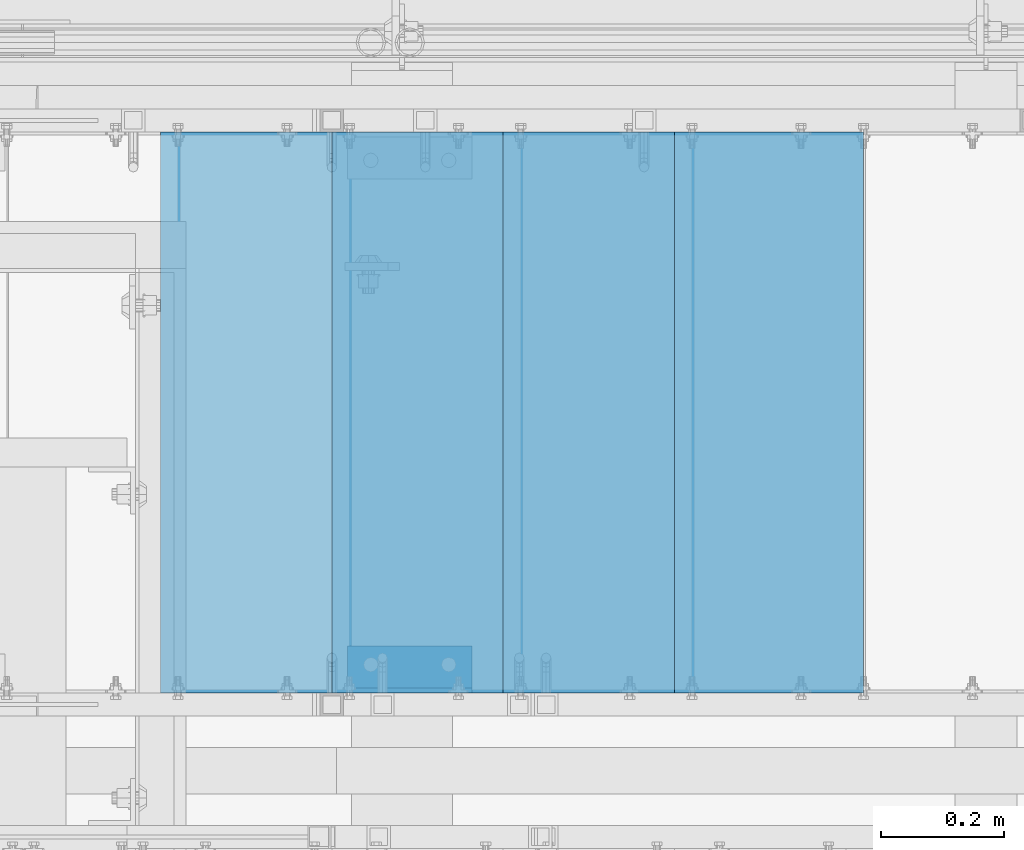
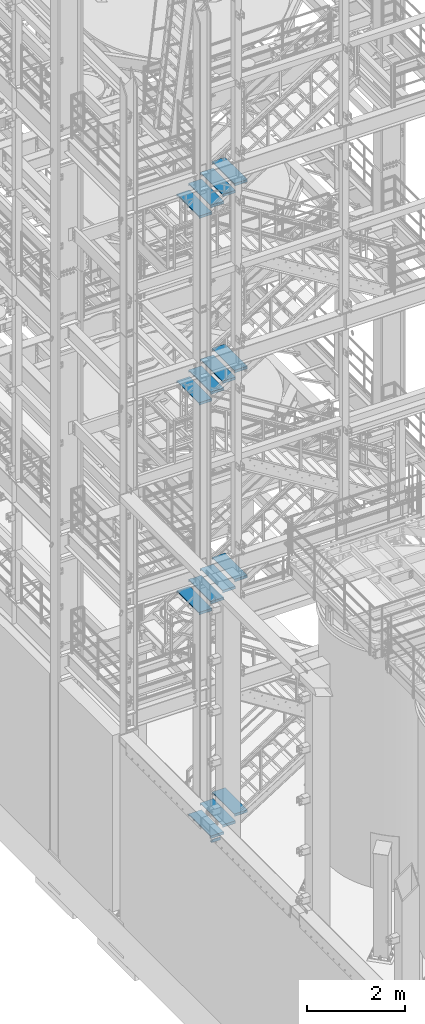
# One storey, part 1171 of 1876: 16 beams, 4 elements without a shape of their own.
"""IFC2X3 building model written with IfcOpenShell, lengths in millimetres."""

from ifc_helpers import new_model, si_unit, frame, origin_with_axes, place, context, subcontext, project, spatial, faceted_brep, material, type_object, element, aggregate, save


model = new_model("IFC2X3")

# Units and contexts
model_context = context("Model", 3, precision=1e-05, world=origin_with_axes())
body_context = subcontext(model_context, "Body", "Model", "MODEL_VIEW")
ifc_project = project(units=[si_unit("LENGTHUNIT", "METRE", prefix="MILLI"), si_unit("AREAUNIT", "SQUARE_METRE"), si_unit("VOLUMEUNIT", "CUBIC_METRE"), si_unit("MASSUNIT", "GRAM", prefix="KILO"), si_unit("TIMEUNIT", "SECOND"), si_unit("PLANEANGLEUNIT", "RADIAN"), si_unit("SOLIDANGLEUNIT", "STERADIAN"), si_unit("THERMODYNAMICTEMPERATUREUNIT", "DEGREE_CELSIUS"), si_unit("LUMINOUSINTENSITYUNIT", "LUMEN")], contexts=[model_context])

# Site, building, storey
site_placement = place(None, origin_with_axes())
site = spatial("IfcSite", under=ifc_project, at=site_placement, CompositionType="ELEMENT")
building_placement = place(site_placement, origin_with_axes())
building = spatial("IfcBuilding", under=site, at=building_placement, Name="Undefined", CompositionType="ELEMENT")
storey_placement = place(building_placement, origin_with_axes())
storey = spatial("IfcBuildingStorey", under=building, at=storey_placement, Name="Undefined", CompositionType="ELEMENT", Elevation=0.0)

# Assembly, beams
assembly_1_placement = place(storey_placement, origin_with_axes())
assembly_1 = element("IfcElementAssembly", 1, at=assembly_1_placement, inside=storey, Name="STRINGER", AssemblyPlace="NOTDEFINED", PredefinedType="RIGID_FRAME")
ifc_material = material(Name="STEEL/A36")
beam_type_1 = type_object("IfcBeamType", PredefinedType="NOTDEFINED")
beam_1_placement = place(assembly_1_placement, frame((3455.98749495745, -5710.23700114638, 16252.2370370816), z_axis=(-1.0, 0.0, 0.0), x_axis=(0.0, 1.0, 0.0)))
beam_1 = element("IfcBeam", 2, at=beam_1_placement, type_object=beam_type_1, material=ifc_material, Name="TREAD", context=body_context, shape_type="Brep", body=[
    faceted_brep([(-7.45785655453801e-11, 53.9750000000167, -153.9875), (-7.45785655453801e-11, 53.9750000000167, 153.987506103515), (0.0, 9.52499999999964, 153.9875), (-7.45785655453801e-11, 9.52499999999964, -153.9875), (-4.76300000007541, 53.9750000000167, -153.9875), (-4.76300000007541, 53.9750000000167, 153.987506103515), (-4.76300000007541, -9.52499999998327, -153.9875), (-4.76300000007541, -9.52500000019427, 153.987536621094), (909.637000008669, -9.52500000248983, 153.987506103515), (909.637000008669, 53.9749999975102, 153.987506103515), (904.87400000867, 53.9749999975102, 153.987506103515), (904.87400000867, 9.52499999999964, 153.987506103515), (-7.45785655453801e-11, -9.52500000019427, 153.987536621094), (904.87400000867, -9.52500000248983, 153.987506103515), (904.87400000867, 9.52499999999964, -153.9875), (909.637000008669, -9.52500000248983, -153.9875), (909.637000008669, 53.9749999975102, -153.9875), (904.87400000867, 53.9749999975102, -153.9875)], [[[0, 1, 2, 3]], [[1, 0, 4, 5]], [[5, 4, 6, 7]], [[8, 9, 10, 11, 2, 1, 5, 7, 12, 13]], [[14, 3, 2, 11]], [[15, 8, 13, 12, 7, 6]], [[9, 16, 17, 10]], [[16, 9, 8, 15]], [[16, 15, 6, 4, 0, 3, 14, 17]], [[10, 17, 14, 11]]]),
])
beam_2_placement = place(assembly_1_placement, frame((3176.58749471172, -5710.23700114703, 16079.1407406735), z_axis=(-1.0, 0.0, 0.0), x_axis=(0.0, 1.0, 0.0)))
beam_2 = element("IfcBeam", 3, at=beam_2_placement, type_object=beam_type_1, material=ifc_material, Name="TREAD", context=body_context, shape_type="Brep", body=[
    faceted_brep([(-7.45785655453801e-11, 53.9750000000167, -153.9875), (-7.45785655453801e-11, 53.9750000000167, 153.987506103515), (0.0, 9.52499999999964, 153.9875), (-7.45785655453801e-11, 9.52499999999964, -153.9875), (-4.76300000007541, 53.9750000000167, -153.9875), (-4.76300000007541, 53.9750000000167, 153.987506103515), (-4.76300000007541, -9.52499999998327, -153.9875), (-4.76300000007541, -9.52500000019427, 153.987536621094), (909.637000008669, -9.52500000248983, 153.987506103515), (909.637000008669, 53.9749999975102, 153.987506103515), (904.87400000867, 53.9749999975102, 153.987506103515), (904.87400000867, 9.52499999999964, 153.987506103515), (-7.45785655453801e-11, -9.52500000019427, 153.987536621094), (904.87400000867, -9.52500000248983, 153.987506103515), (904.87400000867, 9.52499999999964, -153.9875), (909.637000008669, -9.52500000248983, -153.9875), (909.637000008669, 53.9749999975102, -153.9875), (904.87400000867, 53.9749999975102, -153.9875)], [[[0, 1, 2, 3]], [[1, 0, 4, 5]], [[5, 4, 6, 7]], [[8, 9, 10, 11, 2, 1, 5, 7, 12, 13]], [[14, 3, 2, 11]], [[15, 8, 13, 12, 7, 6]], [[9, 16, 17, 10]], [[16, 9, 8, 15]], [[16, 15, 6, 4, 0, 3, 14, 17]], [[10, 17, 14, 11]]]),
])
beam_3_placement = place(assembly_1_placement, frame((2897.187494466, -5710.23700114744, 15906.0444442653), z_axis=(-1.0, 0.0, 0.0), x_axis=(0.0, 1.0, 0.0)))
beam_3 = element("IfcBeam", 4, at=beam_3_placement, type_object=beam_type_1, material=ifc_material, Name="TREAD", context=body_context, shape_type="Brep", body=[
    faceted_brep([(-7.45785655453801e-11, 53.9750000000167, -153.9875), (-7.45785655453801e-11, 53.9750000000167, 153.987506103515), (0.0, 9.52499999999964, 153.9875), (-7.45785655453801e-11, 9.52499999999964, -153.9875), (-4.76300000007541, 53.9750000000167, -153.9875), (-4.76300000007541, 53.9750000000167, 153.987506103515), (-4.76300000007541, -9.52499999998327, -153.9875), (-4.76300000007541, -9.52500000019427, 153.987536621094), (909.637000008669, -9.52500000248983, 153.987506103515), (909.637000008669, 53.9749999975102, 153.987506103515), (904.87400000867, 53.9749999975102, 153.987506103515), (904.87400000867, 9.52499999999964, 153.987506103515), (-7.45785655453801e-11, -9.52500000019427, 153.987536621094), (904.87400000867, -9.52500000248983, 153.987506103515), (904.87400000867, 9.52499999999964, -153.9875), (909.637000008669, -9.52500000248983, -153.9875), (909.637000008669, 53.9749999975102, -153.9875), (904.87400000867, 53.9749999975102, -153.9875)], [[[0, 1, 2, 3]], [[1, 0, 4, 5]], [[5, 4, 6, 7]], [[8, 9, 10, 11, 2, 1, 5, 7, 12, 13]], [[14, 3, 2, 11]], [[15, 8, 13, 12, 7, 6]], [[9, 16, 17, 10]], [[16, 9, 8, 15]], [[16, 15, 6, 4, 0, 3, 14, 17]], [[10, 17, 14, 11]]]),
])
beam_4_placement = place(assembly_1_placement, frame((2617.78749422027, -5710.23700114809, 15732.9481478571), z_axis=(-1.0, 0.0, 0.0), x_axis=(0.0, 1.0, 0.0)))
beam_4 = element("IfcBeam", 5, at=beam_4_placement, type_object=beam_type_1, material=ifc_material, Name="TREAD", context=body_context, shape_type="Brep", body=[
    faceted_brep([(-7.45785655453801e-11, 53.9750000000167, -153.9875), (-7.45785655453801e-11, 53.9750000000167, 153.987506103515), (0.0, 9.52499999999964, 153.9875), (-7.45785655453801e-11, 9.52499999999964, -153.9875), (-4.76300000007541, 53.9750000000167, -153.9875), (-4.76300000007541, 53.9750000000167, 153.987506103515), (-4.76300000007541, -9.52499999998327, -153.9875), (-4.76300000007541, -9.52500000019427, 153.987536621094), (909.637000008669, -9.52500000248983, 153.987506103515), (909.637000008669, 53.9749999975102, 153.987506103515), (904.87400000867, 53.9749999975102, 153.987506103515), (904.87400000867, 9.52499999999964, 153.987506103515), (-7.45785655453801e-11, -9.52500000019427, 153.987536621094), (904.87400000867, -9.52500000248983, 153.987506103515), (904.87400000867, 9.52499999999964, -153.9875), (909.637000008669, -9.52500000248983, -153.9875), (909.637000008669, 53.9749999975102, -153.9875), (904.87400000867, 53.9749999975102, -153.9875)], [[[0, 1, 2, 3]], [[1, 0, 4, 5]], [[5, 4, 6, 7]], [[8, 9, 10, 11, 2, 1, 5, 7, 12, 13]], [[14, 3, 2, 11]], [[15, 8, 13, 12, 7, 6]], [[9, 16, 17, 10]], [[16, 9, 8, 15]], [[16, 15, 6, 4, 0, 3, 14, 17]], [[10, 17, 14, 11]]]),
])
aggregate(assembly_1, [beam_1, beam_2, beam_3, beam_4])

assembly_2_placement = place(storey_placement, origin_with_axes())
assembly_2 = element("IfcElementAssembly", 6, at=assembly_2_placement, inside=storey, Name="STRINGER", AssemblyPlace="NOTDEFINED", PredefinedType="RIGID_FRAME")
beam_5_placement = place(assembly_2_placement, frame((3455.98750092865, -5710.23700114556, 11590.8666666865), z_axis=(-1.0, 0.0, 0.0), x_axis=(0.0, 1.0, 0.0)))
beam_5 = element("IfcBeam", 7, at=beam_5_placement, type_object=beam_type_1, material=ifc_material, Name="TREAD", context=body_context, shape_type="Brep", body=[
    faceted_brep([(-7.45785655453801e-11, 53.9750000000167, -153.9875), (-7.45785655453801e-11, 53.9750000000167, 153.987506103515), (0.0, 9.52499999999964, 153.9875), (-7.45785655453801e-11, 9.52499999999964, -153.9875), (-4.76300000007541, 53.9750000000167, -153.9875), (-4.76300000007541, 53.9750000000167, 153.987506103515), (-4.76300000007541, -9.52499999998327, -153.9875), (-4.76300000007541, -9.52500000019427, 153.987536621094), (909.637000008669, -9.52500000248983, 153.987506103515), (909.637000008669, 53.9749999975102, 153.987506103515), (904.87400000867, 53.9749999975102, 153.987506103515), (904.87400000867, 9.52499999999964, 153.987506103515), (-7.45785655453801e-11, -9.52500000019427, 153.987536621094), (904.87400000867, -9.52500000248983, 153.987506103515), (904.87400000867, 9.52499999999964, -153.9875), (909.637000008669, -9.52500000248983, -153.9875), (909.637000008669, 53.9749999975102, -153.9875), (904.87400000867, 53.9749999975102, -153.9875)], [[[0, 1, 2, 3]], [[1, 0, 4, 5]], [[5, 4, 6, 7]], [[8, 9, 10, 11, 2, 1, 5, 7, 12, 13]], [[14, 3, 2, 11]], [[15, 8, 13, 12, 7, 6]], [[9, 16, 17, 10]], [[16, 9, 8, 15]], [[16, 15, 6, 4, 0, 3, 14, 17]], [[10, 17, 14, 11]]]),
])
beam_6_placement = place(assembly_2_placement, frame((3176.58750102237, -5710.23700114556, 11418.9933333532), z_axis=(-1.0, 0.0, 0.0), x_axis=(0.0, 1.0, 0.0)))
beam_6 = element("IfcBeam", 8, at=beam_6_placement, type_object=beam_type_1, material=ifc_material, Name="TREAD", context=body_context, shape_type="Brep", body=[
    faceted_brep([(-7.45785655453801e-11, 53.9750000000167, -153.9875), (-7.45785655453801e-11, 53.9750000000167, 153.987506103515), (0.0, 9.52499999999964, 153.9875), (-7.45785655453801e-11, 9.52499999999964, -153.9875), (-4.76300000007541, 53.9750000000167, -153.9875), (-4.76300000007541, 53.9750000000167, 153.987506103515), (-4.76300000007541, -9.52499999998327, -153.9875), (-4.76300000007541, -9.52500000019427, 153.987536621094), (909.637000008669, -9.52500000248983, 153.987506103515), (909.637000008669, 53.9749999975102, 153.987506103515), (904.87400000867, 53.9749999975102, 153.987506103515), (904.87400000867, 9.52499999999964, 153.987506103515), (-7.45785655453801e-11, -9.52500000019427, 153.987536621094), (904.87400000867, -9.52500000248983, 153.987506103515), (904.87400000867, 9.52499999999964, -153.9875), (909.637000008669, -9.52500000248983, -153.9875), (909.637000008669, 53.9749999975102, -153.9875), (904.87400000867, 53.9749999975102, -153.9875)], [[[0, 1, 2, 3]], [[1, 0, 4, 5]], [[5, 4, 6, 7]], [[8, 9, 10, 11, 2, 1, 5, 7, 12, 13]], [[14, 3, 2, 11]], [[15, 8, 13, 12, 7, 6]], [[9, 16, 17, 10]], [[16, 9, 8, 15]], [[16, 15, 6, 4, 0, 3, 14, 17]], [[10, 17, 14, 11]]]),
])
beam_7_placement = place(assembly_2_placement, frame((2897.1875011161, -5710.23700114556, 11247.1200000199), z_axis=(-1.0, 0.0, 0.0), x_axis=(0.0, 1.0, 0.0)))
beam_7 = element("IfcBeam", 9, at=beam_7_placement, type_object=beam_type_1, material=ifc_material, Name="TREAD", context=body_context, shape_type="Brep", body=[
    faceted_brep([(-7.45785655453801e-11, 53.9750000000167, -153.9875), (-7.45785655453801e-11, 53.9750000000167, 153.987506103515), (0.0, 9.52499999999964, 153.9875), (-7.45785655453801e-11, 9.52499999999964, -153.9875), (-4.76300000007541, 53.9750000000167, -153.9875), (-4.76300000007541, 53.9750000000167, 153.987506103515), (-4.76300000007541, -9.52499999998327, -153.9875), (-4.76300000007541, -9.52500000019427, 153.987536621094), (909.637000008669, -9.52500000248983, 153.987506103515), (909.637000008669, 53.9749999975102, 153.987506103515), (904.87400000867, 53.9749999975102, 153.987506103515), (904.87400000867, 9.52499999999964, 153.987506103515), (-7.45785655453801e-11, -9.52500000019427, 153.987536621094), (904.87400000867, -9.52500000248983, 153.987506103515), (904.87400000867, 9.52499999999964, -153.9875), (909.637000008669, -9.52500000248983, -153.9875), (909.637000008669, 53.9749999975102, -153.9875), (904.87400000867, 53.9749999975102, -153.9875)], [[[0, 1, 2, 3]], [[1, 0, 4, 5]], [[5, 4, 6, 7]], [[8, 9, 10, 11, 2, 1, 5, 7, 12, 13]], [[14, 3, 2, 11]], [[15, 8, 13, 12, 7, 6]], [[9, 16, 17, 10]], [[16, 9, 8, 15]], [[16, 15, 6, 4, 0, 3, 14, 17]], [[10, 17, 14, 11]]]),
])
beam_8_placement = place(assembly_2_placement, frame((2617.78750120982, -5710.23700114556, 11075.2466666865), z_axis=(-1.0, 0.0, 0.0), x_axis=(0.0, 1.0, 0.0)))
beam_8 = element("IfcBeam", 10, at=beam_8_placement, type_object=beam_type_1, material=ifc_material, Name="TREAD", context=body_context, shape_type="Brep", body=[
    faceted_brep([(-7.45785655453801e-11, 53.9750000000167, -153.9875), (-7.45785655453801e-11, 53.9750000000167, 153.987506103515), (0.0, 9.52499999999964, 153.9875), (-7.45785655453801e-11, 9.52499999999964, -153.9875), (-4.76300000007541, 53.9750000000167, -153.9875), (-4.76300000007541, 53.9750000000167, 153.987506103515), (-4.76300000007541, -9.52499999998327, -153.9875), (-4.76300000007541, -9.52500000019427, 153.987536621094), (909.637000008669, -9.52500000248983, 153.987506103515), (909.637000008669, 53.9749999975102, 153.987506103515), (904.87400000867, 53.9749999975102, 153.987506103515), (904.87400000867, 9.52499999999964, 153.987506103515), (-7.45785655453801e-11, -9.52500000019427, 153.987536621094), (904.87400000867, -9.52500000248983, 153.987506103515), (904.87400000867, 9.52499999999964, -153.9875), (909.637000008669, -9.52500000248983, -153.9875), (909.637000008669, 53.9749999975102, -153.9875), (904.87400000867, 53.9749999975102, -153.9875)], [[[0, 1, 2, 3]], [[1, 0, 4, 5]], [[5, 4, 6, 7]], [[8, 9, 10, 11, 2, 1, 5, 7, 12, 13]], [[14, 3, 2, 11]], [[15, 8, 13, 12, 7, 6]], [[9, 16, 17, 10]], [[16, 9, 8, 15]], [[16, 15, 6, 4, 0, 3, 14, 17]], [[10, 17, 14, 11]]]),
])
aggregate(assembly_2, [beam_5, beam_6, beam_7, beam_8])

assembly_3_placement = place(storey_placement, origin_with_axes())
assembly_3 = element("IfcElementAssembly", 11, at=assembly_3_placement, inside=storey, Name="STRINGER", AssemblyPlace="NOTDEFINED", PredefinedType="RIGID_FRAME")
beam_9_placement = place(assembly_3_placement, frame((3455.98749797608, -5710.23700113625, 6375.39999943381), z_axis=(-1.0, 0.0, 0.0), x_axis=(0.0, 1.0, 0.0)))
beam_9 = element("IfcBeam", 12, at=beam_9_placement, type_object=beam_type_1, material=ifc_material, Name="TREAD", context=body_context, shape_type="Brep", body=[
    faceted_brep([(-7.45785655453801e-11, 53.9750000000167, -153.9875), (-7.45785655453801e-11, 53.9750000000167, 153.987506103515), (0.0, 9.52499999999964, 153.9875), (-7.45785655453801e-11, 9.52499999999964, -153.9875), (-4.76300000007541, 53.9750000000167, -153.9875), (-4.76300000007541, 53.9750000000167, 153.987506103515), (-4.76300000007541, -9.52499999998327, -153.9875), (-4.76300000007541, -9.52500000019427, 153.987536621094), (909.637000008669, -9.52500000248983, 153.987506103515), (909.637000008669, 53.9749999975102, 153.987506103515), (904.87400000867, 53.9749999975102, 153.987506103515), (904.87400000867, 9.52499999999964, 153.987506103515), (-7.45785655453801e-11, -9.52500000019427, 153.987536621094), (904.87400000867, -9.52500000248983, 153.987506103515), (904.87400000867, 9.52499999999964, -153.9875), (909.637000008669, -9.52500000248983, -153.9875), (909.637000008669, 53.9749999975102, -153.9875), (904.87400000867, 53.9749999975102, -153.9875)], [[[0, 1, 2, 3]], [[1, 0, 4, 5]], [[5, 4, 6, 7]], [[8, 9, 10, 11, 2, 1, 5, 7, 12, 13]], [[14, 3, 2, 11]], [[15, 8, 13, 12, 7, 6]], [[9, 16, 17, 10]], [[16, 9, 8, 15]], [[16, 15, 6, 4, 0, 3, 14, 17]], [[10, 17, 14, 11]]]),
])
beam_10_placement = place(assembly_3_placement, frame((3176.58749836618, -5710.23700113625, 6197.59999951457), z_axis=(-1.0, 0.0, 0.0), x_axis=(0.0, 1.0, 0.0)))
beam_10 = element("IfcBeam", 13, at=beam_10_placement, type_object=beam_type_1, material=ifc_material, Name="TREAD", context=body_context, shape_type="Brep", body=[
    faceted_brep([(-7.45785655453801e-11, 53.9750000000167, -153.9875), (-7.45785655453801e-11, 53.9750000000167, 153.987506103515), (0.0, 9.52499999999964, 153.9875), (-7.45785655453801e-11, 9.52499999999964, -153.9875), (-4.76300000007541, 53.9750000000167, -153.9875), (-4.76300000007541, 53.9750000000167, 153.987506103515), (-4.76300000007541, -9.52499999998327, -153.9875), (-4.76300000007541, -9.52500000019427, 153.987536621094), (909.637000008669, -9.52500000248983, 153.987506103515), (909.637000008669, 53.9749999975102, 153.987506103515), (904.87400000867, 53.9749999975102, 153.987506103515), (904.87400000867, 9.52499999999964, 153.987506103515), (-7.45785655453801e-11, -9.52500000019427, 153.987536621094), (904.87400000867, -9.52500000248983, 153.987506103515), (904.87400000867, 9.52499999999964, -153.9875), (909.637000008669, -9.52500000248983, -153.9875), (909.637000008669, 53.9749999975102, -153.9875), (904.87400000867, 53.9749999975102, -153.9875)], [[[0, 1, 2, 3]], [[1, 0, 4, 5]], [[5, 4, 6, 7]], [[8, 9, 10, 11, 2, 1, 5, 7, 12, 13]], [[14, 3, 2, 11]], [[15, 8, 13, 12, 7, 6]], [[9, 16, 17, 10]], [[16, 9, 8, 15]], [[16, 15, 6, 4, 0, 3, 14, 17]], [[10, 17, 14, 11]]]),
])
beam_11_placement = place(assembly_3_placement, frame((2897.18749875627, -5710.23700113625, 6019.79999959534), z_axis=(-1.0, 0.0, 0.0), x_axis=(0.0, 1.0, 0.0)))
beam_11 = element("IfcBeam", 14, at=beam_11_placement, type_object=beam_type_1, material=ifc_material, Name="TREAD", context=body_context, shape_type="Brep", body=[
    faceted_brep([(-7.45785655453801e-11, 53.9750000000167, -153.9875), (-7.45785655453801e-11, 53.9750000000167, 153.987506103515), (0.0, 9.52499999999964, 153.9875), (-7.45785655453801e-11, 9.52499999999964, -153.9875), (-4.76300000007541, 53.9750000000167, -153.9875), (-4.76300000007541, 53.9750000000167, 153.987506103515), (-4.76300000007541, -9.52499999998327, -153.9875), (-4.76300000007541, -9.52500000019427, 153.987536621094), (909.637000008669, -9.52500000248983, 153.987506103515), (909.637000008669, 53.9749999975102, 153.987506103515), (904.87400000867, 53.9749999975102, 153.987506103515), (904.87400000867, 9.52499999999964, 153.987506103515), (-7.45785655453801e-11, -9.52500000019427, 153.987536621094), (904.87400000867, -9.52500000248983, 153.987506103515), (904.87400000867, 9.52499999999964, -153.9875), (909.637000008669, -9.52500000248983, -153.9875), (909.637000008669, 53.9749999975102, -153.9875), (904.87400000867, 53.9749999975102, -153.9875)], [[[0, 1, 2, 3]], [[1, 0, 4, 5]], [[5, 4, 6, 7]], [[8, 9, 10, 11, 2, 1, 5, 7, 12, 13]], [[14, 3, 2, 11]], [[15, 8, 13, 12, 7, 6]], [[9, 16, 17, 10]], [[16, 9, 8, 15]], [[16, 15, 6, 4, 0, 3, 14, 17]], [[10, 17, 14, 11]]]),
])
beam_12_placement = place(assembly_3_placement, frame((2617.78749914636, -5710.23700113625, 5841.99999967611), z_axis=(-1.0, 0.0, 0.0), x_axis=(0.0, 1.0, 0.0)))
beam_12 = element("IfcBeam", 15, at=beam_12_placement, type_object=beam_type_1, material=ifc_material, Name="TREAD", context=body_context, shape_type="Brep", body=[
    faceted_brep([(-7.45785655453801e-11, 53.9750000000167, -153.9875), (-7.45785655453801e-11, 53.9750000000167, 153.987506103515), (0.0, 9.52499999999964, 153.9875), (-7.45785655453801e-11, 9.52499999999964, -153.9875), (-4.76300000007541, 53.9750000000167, -153.9875), (-4.76300000007541, 53.9750000000167, 153.987506103515), (-4.76300000007541, -9.52499999998327, -153.9875), (-4.76300000007541, -9.52500000019427, 153.987536621094), (909.637000008669, -9.52500000248983, 153.987506103515), (909.637000008669, 53.9749999975102, 153.987506103515), (904.87400000867, 53.9749999975102, 153.987506103515), (904.87400000867, 9.52499999999964, 153.987506103515), (-7.45785655453801e-11, -9.52500000019427, 153.987536621094), (904.87400000867, -9.52500000248983, 153.987506103515), (904.87400000867, 9.52499999999964, -153.9875), (909.637000008669, -9.52500000248983, -153.9875), (909.637000008669, 53.9749999975102, -153.9875), (904.87400000867, 53.9749999975102, -153.9875)], [[[0, 1, 2, 3]], [[1, 0, 4, 5]], [[5, 4, 6, 7]], [[8, 9, 10, 11, 2, 1, 5, 7, 12, 13]], [[14, 3, 2, 11]], [[15, 8, 13, 12, 7, 6]], [[9, 16, 17, 10]], [[16, 9, 8, 15]], [[16, 15, 6, 4, 0, 3, 14, 17]], [[10, 17, 14, 11]]]),
])
aggregate(assembly_3, [beam_9, beam_10, beam_11, beam_12])

assembly_4_placement = place(storey_placement, origin_with_axes())
assembly_4 = element("IfcElementAssembly", 16, at=assembly_4_placement, inside=storey, Name="STRINGER", AssemblyPlace="NOTDEFINED", PredefinedType="RIGID_FRAME")
beam_13_placement = place(assembly_4_placement, frame((3455.98750041734, -5710.23700121136, 522.232758491591), z_axis=(-1.0, 0.0, 0.0), x_axis=(0.0, 1.0, 0.0)))
beam_13 = element("IfcBeam", 17, at=beam_13_placement, type_object=beam_type_1, material=ifc_material, Name="TREAD", context=body_context, shape_type="Brep", body=[
    faceted_brep([(-7.45785655453801e-11, 53.9750000000167, -153.9875), (-7.45785655453801e-11, 53.9750000000167, 153.987506103515), (0.0, 9.52499999999964, 153.9875), (-7.45785655453801e-11, 9.52499999999964, -153.9875), (-4.76300000007541, 53.9750000000167, -153.9875), (-4.76300000007541, 53.9750000000167, 153.987506103515), (-4.76300000007541, -9.52499999998327, -153.9875), (-4.76300000007541, -9.52500000019427, 153.987536621094), (909.637000008669, -9.52500000248983, 153.987506103515), (909.637000008669, 53.9749999975102, 153.987506103515), (904.87400000867, 53.9749999975102, 153.987506103515), (904.87400000867, 9.52499999999964, 153.987506103515), (-7.45785655453801e-11, -9.52500000019427, 153.987536621094), (904.87400000867, -9.52500000248983, 153.987506103515), (904.87400000867, 9.52499999999964, -153.9875), (909.637000008669, -9.52500000248983, -153.9875), (909.637000008669, 53.9749999975102, -153.9875), (904.87400000867, 53.9749999975102, -153.9875)], [[[0, 1, 2, 3]], [[1, 0, 4, 5]], [[5, 4, 6, 7]], [[8, 9, 10, 11, 2, 1, 5, 7, 12, 13]], [[14, 3, 2, 11]], [[15, 8, 13, 12, 7, 6]], [[9, 16, 17, 10]], [[16, 9, 8, 15]], [[16, 15, 6, 4, 0, 3, 14, 17]], [[10, 17, 14, 11]]]),
])
beam_14_placement = place(assembly_4_placement, frame((3176.58750039017, -5710.23700121136, 344.980172327548), z_axis=(-1.0, 0.0, 0.0), x_axis=(0.0, 1.0, 0.0)))
beam_14 = element("IfcBeam", 18, at=beam_14_placement, type_object=beam_type_1, material=ifc_material, Name="TREAD", context=body_context, shape_type="Brep", body=[
    faceted_brep([(-7.45785655453801e-11, 53.9750000000167, -153.9875), (-7.45785655453801e-11, 53.9750000000167, 153.987506103515), (0.0, 9.52499999999964, 153.9875), (-7.45785655453801e-11, 9.52499999999964, -153.9875), (-4.76300000007541, 53.9750000000167, -153.9875), (-4.76300000007541, 53.9750000000167, 153.987506103515), (-4.76300000007541, -9.52499999998327, -153.9875), (-4.76300000007541, -9.52500000019427, 153.987536621094), (909.637000008669, -9.52500000248983, 153.987506103515), (909.637000008669, 53.9749999975102, 153.987506103515), (904.87400000867, 53.9749999975102, 153.987506103515), (904.87400000867, 9.52499999999964, 153.987506103515), (-7.45785655453801e-11, -9.52500000019427, 153.987536621094), (904.87400000867, -9.52500000248983, 153.987506103515), (904.87400000867, 9.52499999999964, -153.9875), (909.637000008669, -9.52500000248983, -153.9875), (909.637000008669, 53.9749999975102, -153.9875), (904.87400000867, 53.9749999975102, -153.9875)], [[[0, 1, 2, 3]], [[1, 0, 4, 5]], [[5, 4, 6, 7]], [[8, 9, 10, 11, 2, 1, 5, 7, 12, 13]], [[14, 3, 2, 11]], [[15, 8, 13, 12, 7, 6]], [[9, 16, 17, 10]], [[16, 9, 8, 15]], [[16, 15, 6, 4, 0, 3, 14, 17]], [[10, 17, 14, 11]]]),
])
beam_15_placement = place(assembly_4_placement, frame((2897.187500363, -5710.23700121136, 167.727586163492), z_axis=(-1.0, 0.0, 0.0), x_axis=(0.0, 1.0, 0.0)))
beam_15 = element("IfcBeam", 19, at=beam_15_placement, type_object=beam_type_1, material=ifc_material, Name="TREAD", context=body_context, shape_type="Brep", body=[
    faceted_brep([(-7.45785655453801e-11, 53.9750000000167, -153.9875), (-7.45785655453801e-11, 53.9750000000167, 153.987506103515), (0.0, 9.52499999999964, 153.9875), (-7.45785655453801e-11, 9.52499999999964, -153.9875), (-4.76300000007541, 53.9750000000167, -153.9875), (-4.76300000007541, 53.9750000000167, 153.987506103515), (-4.76300000007541, -9.52499999998327, -153.9875), (-4.76300000007541, -9.52500000019427, 153.987536621094), (909.637000008669, -9.52500000248983, 153.987506103515), (909.637000008669, 53.9749999975102, 153.987506103515), (904.87400000867, 53.9749999975102, 153.987506103515), (904.87400000867, 9.52499999999964, 153.987506103515), (-7.45785655453801e-11, -9.52500000019427, 153.987536621094), (904.87400000867, -9.52500000248983, 153.987506103515), (904.87400000867, 9.52499999999964, -153.9875), (909.637000008669, -9.52500000248983, -153.9875), (909.637000008669, 53.9749999975102, -153.9875), (904.87400000867, 53.9749999975102, -153.9875)], [[[0, 1, 2, 3]], [[1, 0, 4, 5]], [[5, 4, 6, 7]], [[8, 9, 10, 11, 2, 1, 5, 7, 12, 13]], [[14, 3, 2, 11]], [[15, 8, 13, 12, 7, 6]], [[9, 16, 17, 10]], [[16, 9, 8, 15]], [[16, 15, 6, 4, 0, 3, 14, 17]], [[10, 17, 14, 11]]]),
])
beam_type_2 = type_object("IfcBeamType", Name="L3X3X5/16", PredefinedType="NOTDEFINED")
beam_16_placement = place(assembly_4_placement, frame((2768.60000033285, -5676.90000121165, 38.0179379310037), z_axis=(0.0, 1.0, 0.0), x_axis=(1.0, 0.0, 0.0)))
beam_16 = element("IfcBeam", 20, at=beam_16_placement, type_object=beam_type_2, material=ifc_material, Name="ANGLE", ObjectType="L3X3X5/16", context=body_context, shape_type="Brep", body=[
    faceted_brep([(0.0, 38.1000000000004, -38.1), (0.0, 38.1000000000004, 38.1), (203.2, 38.1, 38.1000000000004), (203.2, 38.1, -38.1000000000004), (0.0, 30.1625, 38.1000000000004), (203.2, 30.1625, 38.1000000000004), (0.0, 30.1625, -30.1625000000004), (203.2, 30.1625, -30.1625000000004), (0.0, -38.1, -30.1625000000004), (203.2, -38.1, -30.1625000000004), (0.0, -38.1000000000004, -38.1), (203.2, -38.1, -38.1000000000004)], [[[0, 1, 2, 3]], [[1, 4, 5, 2]], [[4, 6, 7, 5]], [[6, 8, 9, 7]], [[8, 10, 11, 9]], [[10, 0, 3, 11]], [[5, 7, 9, 11, 3, 2]], [[10, 8, 6, 4, 1, 0]]]),
])
aggregate(assembly_4, [beam_13, beam_14, beam_15, beam_16])

save(model, "model.ifc")
